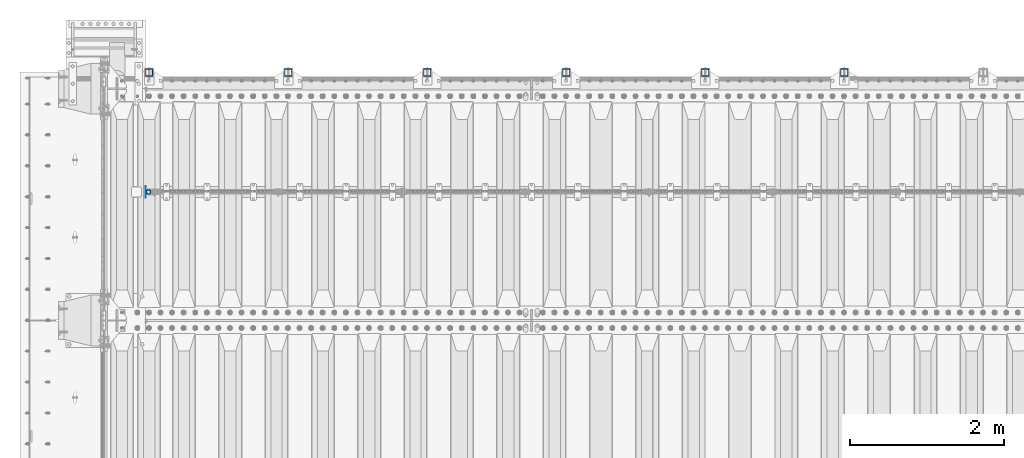
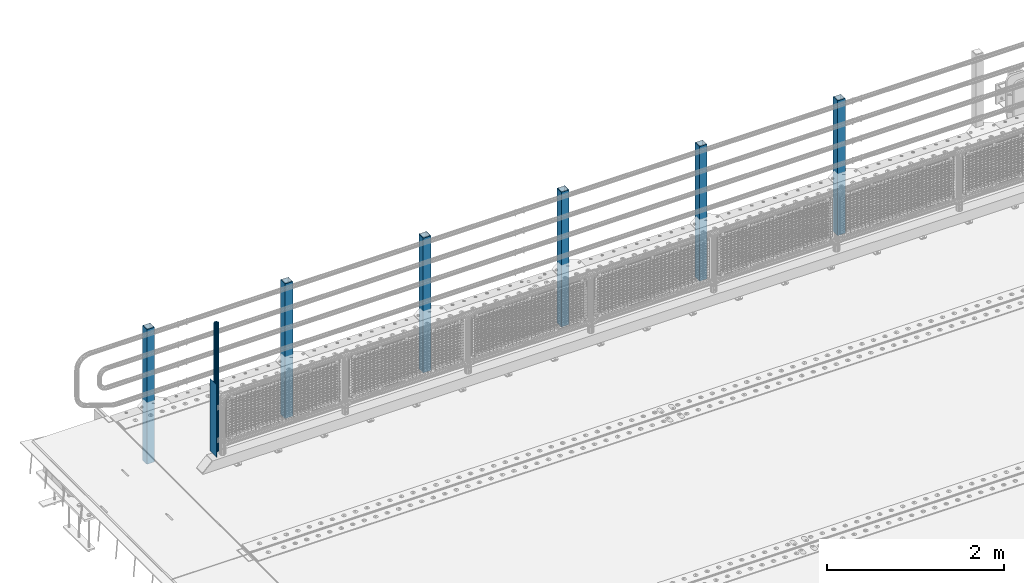
# One storey, part 61 of 257: 8 columns.
"""IFC2X3 building model written with IfcOpenShell, lengths in millimetres."""

import ifcopenshell
import ifcopenshell.guid

model = None  # the IFC model being written
_history = None  # IfcOwnerHistory: only IFC2X3 demands one
_inside = {}  # id of a spatial element -> (the spatial element, [elements in it])
_under = {}  # id of a project, library or spatial element -> (it, [spatial elements below it])
_declared = {}  # id of a project -> (the project, [libraries it declares])
_typed = {}  # id of a type object -> (the type object, [elements of that type])
_made_of = {}  # id of a material, layer set ... -> (it, [elements and type objects made of it])


def new_model(schema):
    """Start an empty IFC model of exactly this schema.

    Asked for "IFC4X3", IfcOpenShell would pick the latest addendum, in which some entities
    have other attributes; the version numbers below select the first issue.
    IFC2X3 requires an IfcOwnerHistory on every rooted entity: one is made here for all.
    """
    global model, _history
    if schema == "IFC4X3":
        model = ifcopenshell.file(schema_version=(4, 3, 0, 0))
    else:
        model = ifcopenshell.file(schema=schema)
    _inside.clear()
    _under.clear()
    _declared.clear()
    _typed.clear()
    _made_of.clear()
    _history = None
    if model.schema == "IFC2X3":
        org = make("IfcOrganization", Name="unknown")
        user = make(
            "IfcPersonAndOrganization",
            ThePerson=make("IfcPerson", FamilyName="unknown"),
            TheOrganization=org,
        )
        app = make(
            "IfcApplication",
            ApplicationDeveloper=org,
            Version="unknown",
            ApplicationFullName="unknown",
            ApplicationIdentifier="unknown",
        )
        _history = make(
            "IfcOwnerHistory",
            OwningUser=user,
            OwningApplication=app,
            ChangeAction="ADDED",
            CreationDate=0,
        )
    return model


def make(cls, **values):
    """One entity of the class cls with the attributes given. An attribute that is None is left unset."""
    return model.create_entity(
        cls, **{name: value for name, value in values.items() if value is not None}
    )


def rooted(cls, **values):
    """An entity with a GlobalId (a new one), such as an element, a storey or a relation."""
    return make(cls, GlobalId=ifcopenshell.guid.new(), OwnerHistory=_history, **values)


def si_unit(unit_type, name, prefix=None):
    """IfcSIUnit, for example si_unit("LENGTHUNIT", "METRE", prefix="MILLI")."""
    return make("IfcSIUnit", UnitType=unit_type, Prefix=prefix, Name=name)


def assignment(units):
    """IfcUnitAssignment: the units of a project."""
    return None if units is None else make("IfcUnitAssignment", Units=units)


def point(xyz):
    """IfcCartesianPoint."""
    return None if xyz is None else make("IfcCartesianPoint", Coordinates=xyz)


def direction(xyz):
    """IfcDirection."""
    return None if xyz is None else make("IfcDirection", DirectionRatios=xyz)


def frame(location, z_axis=None, x_axis=None):
    """IfcAxis2Placement3D, a coordinate frame: its origin and axes. An axis left out is left unset."""
    return make(
        "IfcAxis2Placement3D",
        Location=point(location),
        Axis=direction(z_axis),
        RefDirection=direction(x_axis),
    )


def origin_with_axes():
    """The frame at (0, 0, 0) with the z axis (0, 0, 1) and the x axis (1, 0, 0) written out."""
    return frame((0.0, 0.0, 0.0), z_axis=(0.0, 0.0, 1.0), x_axis=(1.0, 0.0, 0.0))


def place(relative_to, where):
    """IfcLocalPlacement: puts the frame where relative to a parent placement (None: the world)."""
    return make(
        "IfcLocalPlacement", PlacementRelTo=relative_to, RelativePlacement=where
    )


def context(
    kind, dimensions, precision=None, world=None, true_north=None, identifier=None
):
    """IfcGeometricRepresentationContext, for example the 3D "Model" context."""
    return make(
        "IfcGeometricRepresentationContext",
        ContextIdentifier=identifier,
        ContextType=kind,
        CoordinateSpaceDimension=dimensions,
        Precision=precision,
        WorldCoordinateSystem=world,
        TrueNorth=true_north,
    )


def subcontext(parent, identifier, kind, view, scale=None):
    """IfcGeometricRepresentationSubContext, for example "Body" below "Model"."""
    return make(
        "IfcGeometricRepresentationSubContext",
        ContextIdentifier=identifier,
        ContextType=kind,
        ParentContext=parent,
        TargetScale=scale,
        TargetView=view,
    )


def project(units=None, contexts=None):
    """IfcProject with its units and contexts."""
    return rooted(
        "IfcProject",
        Name="project",
        RepresentationContexts=contexts,
        UnitsInContext=assignment(units),
    )


def spatial(cls, under=None, at=None, **own):
    """A site, building, storey or space (cls), placed at a placement, below another one or the project."""
    s = rooted(cls, ObjectPlacement=at, **own)
    if under is not None:
        _under.setdefault(under.id(), (under, []))[1].append(s)
    return s


def faces_of(points, faces, orient=None, outer=None):
    """IfcFace entities. A face is a list of loops; a loop is a list of indices into points, from 0.

    orient and outer hold one flag for each loop. By default every Orientation is true, the
    first loop of a face is its IfcFaceOuterBound and the others are IfcFaceBound.
    """
    made = []
    for i, loops in enumerate(faces):
        bounds = []
        for j, loop in enumerate(loops):
            is_outer = j == 0 if outer is None else outer[i][j]
            bounds.append(
                make(
                    "IfcFaceOuterBound" if is_outer else "IfcFaceBound",
                    Bound=make("IfcPolyLoop", Polygon=[points[k] for k in loop]),
                    Orientation=True if orient is None else orient[i][j],
                )
            )
        made.append(make("IfcFace", Bounds=bounds))
    return made


def faceted_brep(points, faces, orient=None, outer=None, voids=None):
    """IfcFacetedBrep: a solid bounded by flat faces; with voids (closed shells), ...WithVoids."""
    shared = [point(p) for p in points]
    hull = make("IfcClosedShell", CfsFaces=faces_of(shared, faces, orient, outer))
    if voids is None:
        return make("IfcFacetedBrep", Outer=hull)
    return make(
        "IfcFacetedBrepWithVoids",
        Outer=hull,
        Voids=[
            make(cls, CfsFaces=faces_of(shared, fs, o, b)) for cls, fs, o, b in voids
        ],
    )


def shape(context_of_items, identifier, shape_type, items):
    """IfcShapeRepresentation: the items that make up one representation, for example the "Body"."""
    return make(
        "IfcShapeRepresentation",
        ContextOfItems=context_of_items,
        RepresentationIdentifier=identifier,
        RepresentationType=shape_type,
        Items=items,
    )


def material(Name=None, Category=None):
    """IfcMaterial."""
    return make("IfcMaterial", Name=Name, Category=Category)


def made_of(thing, what):
    """Note that an element or type object is made of a material, layer set ...; save() writes the relation."""
    if what is not None:
        _made_of.setdefault(what.id(), (what, []))[1].append(thing)
    return thing


def type_object(cls, material=None, **own):
    """A type object (cls), such as IfcWallType, which elements share."""
    return made_of(rooted(cls, **own), material)


def element(
    cls,
    number,
    at=None,
    inside=None,
    cuts=None,
    type_object=None,
    material=None,
    context=None,
    identifier="Body",
    shape_type=None,
    held_by="IfcProductDefinitionShape",
    body=None,
    shapes=None,
    **own,
):
    """One element of the class cls, such as IfcWall. Its Tag is "e" and its number.

    at: its placement. inside: the storey or other place that contains it. cuts: it is an
    opening in that element (IfcRelVoidsElement). A single representation is given by context,
    identifier, shape_type and body (its items); several are given by shapes. held_by: the class
    of the entity that holds the representations. save() writes the other relations.
    """
    e = rooted(cls, Tag="e%d" % number, ObjectPlacement=at, **own)
    if body is not None:
        shapes = [shape(context, identifier, shape_type, body)]
    if shapes is not None:
        e.Representation = make(held_by, Representations=shapes)
    if inside is not None:
        _inside.setdefault(inside.id(), (inside, []))[1].append(e)
    if cuts is not None:
        rooted(
            "IfcRelVoidsElement", RelatingBuildingElement=cuts, RelatedOpeningElement=e
        )
    if type_object is not None:
        _typed.setdefault(type_object.id(), (type_object, []))[1].append(e)
    return made_of(e, material)


def aggregate(whole, parts):
    """IfcRelAggregates: a whole, such as a stair, and the parts it consists of."""
    return rooted("IfcRelAggregates", RelatingObject=whole, RelatedObjects=parts)


def save(model, path):
    """Write the relations noted so far, then the file.

    IfcRelAggregates (storeys below a building ...), IfcRelContainedInSpatialStructure (elements
    in a storey), IfcRelDefinesByType, IfcRelAssociatesMaterial and IfcRelDeclares: one each for
    every whole, place, type object, material and project.
    """
    for whole, parts in _under.values():
        aggregate(whole, parts)
    for where, things in _inside.values():
        rooted(
            "IfcRelContainedInSpatialStructure",
            RelatedElements=things,
            RelatingStructure=where,
        )
    for kind, things in _typed.values():
        rooted("IfcRelDefinesByType", RelatedObjects=things, RelatingType=kind)
    for what, things in _made_of.values():
        rooted("IfcRelAssociatesMaterial", RelatedObjects=things, RelatingMaterial=what)
    for by, libraries in _declared.values():
        rooted("IfcRelDeclares", RelatingContext=by, RelatedDefinitions=libraries)
    model.write(path)


model = new_model("IFC2X3")

# Units and contexts
model_context = context("Model", 3, precision=1e-05, world=origin_with_axes())
body_context = subcontext(model_context, "Body", "Model", "MODEL_VIEW")
ifc_project = project(units=[si_unit("LENGTHUNIT", "METRE", prefix="MILLI"), si_unit("AREAUNIT", "SQUARE_METRE"), si_unit("VOLUMEUNIT", "CUBIC_METRE"), si_unit("MASSUNIT", "GRAM", prefix="KILO"), si_unit("TIMEUNIT", "SECOND"), si_unit("PLANEANGLEUNIT", "RADIAN"), si_unit("SOLIDANGLEUNIT", "STERADIAN"), si_unit("THERMODYNAMICTEMPERATUREUNIT", "DEGREE_CELSIUS"), si_unit("LUMINOUSINTENSITYUNIT", "LUMEN")], contexts=[model_context])

# Site, building, storey
site_placement = place(None, origin_with_axes())
site = spatial("IfcSite", under=ifc_project, at=site_placement, CompositionType="ELEMENT")
building_placement = place(site_placement, origin_with_axes())
building = spatial("IfcBuilding", under=site, at=building_placement, Name="Standard", CompositionType="ELEMENT")
storey_placement = place(building_placement, origin_with_axes())
storey = spatial("IfcBuildingStorey", under=building, at=storey_placement, Name="Undefined", CompositionType="ELEMENT", Elevation=0.0)

# Columns
ifc_material_1 = material(Name="Misc_Undefined")
column_type_1 = type_object("IfcColumnType", PredefinedType="NOTDEFINED")
column_1_placement = place(storey_placement, frame((42991.0, 10664.5, 238.02), z_axis=(1.0, 0.0, 0.0), x_axis=(0.0, 0.0, 1.0)))
element("IfcColumn", 1, at=column_1_placement, inside=storey, type_object=column_type_1, material=ifc_material_1, context=body_context, shape_type="Brep", body=[
    faceted_brep([(0.0, -25.3500000000004, 0.0), (0.0, -23.4203461491616, 9.70102501045767), (1761.98, -23.4203461491616, 9.70102501045767), (1761.98, -25.3500000000004, 0.0), (0.0, -17.9251569030785, 17.9251569030821), (1761.98, -17.9251569030785, 17.9251569030821), (0.0, -9.70102501045585, 23.4203461491634), (1761.98, -9.70102501045585, 23.4203461491634), (0.0, 0.0, 25.3499999999985), (1761.98, 0.0, 25.3499999999985), (0.0, 9.70102501045585, 23.4203461491634), (1761.98, 9.70102501045585, 23.4203461491634), (0.0, 17.9251569030785, 17.9251569030821), (1761.98, 17.9251569030785, 17.9251569030821), (0.0, 23.4203461491616, 9.70102501045767), (1761.98, 23.4203461491616, 9.70102501045767), (0.0, 25.3500000000004, 0.0), (1761.98, 25.3500000000004, 0.0), (0.0, 23.4203461491616, -9.70102501045767), (1761.98, 23.4203461491616, -9.70102501045767), (0.0, 17.9251569030785, -17.9251569030821), (1761.98, 17.9251569030785, -17.9251569030821), (0.0, 9.70102501045585, -23.4203461491634), (1761.98, 9.70102501045585, -23.4203461491634), (0.0, 0.0, -25.3499999999985), (1761.98, 0.0, -25.3499999999985), (0.0, -9.70102501045585, -23.4203461491634), (1761.98, -9.70102501045585, -23.4203461491634), (0.0, -17.9251569030785, -17.9251569030821), (1761.98, -17.9251569030785, -17.9251569030821), (0.0, -23.4203461491616, -9.70102501045767), (1761.98, -23.4203461491616, -9.70102501045767), (0.0, -30.1499999999996, 0.0), (0.0, -27.8549679052157, -11.5379054858058), (1761.98, -27.8549679052157, -11.5379054858058), (1761.98, -30.1499999999996, 0.0), (0.0, -21.3192694527752, -21.3192694527752), (1761.98, -21.3192694527752, -21.3192694527752), (0.0, -11.5379054858076, -27.8549679052157), (1761.98, -11.5379054858076, -27.8549679052157), (0.0, 0.0, -30.1500000000015), (1761.98, 0.0, -30.1500000000015), (0.0, 11.5379054858076, -27.8549679052157), (1761.98, 11.5379054858076, -27.8549679052157), (0.0, 21.3192694527752, -21.3192694527752), (1761.98, 21.3192694527752, -21.3192694527752), (0.0, 27.8549679052157, -11.5379054858058), (1761.98, 27.8549679052157, -11.5379054858058), (0.0, 30.1499999999996, 0.0), (1761.98, 30.1499999999996, 0.0), (0.0, 27.8549679052157, 11.5379054858058), (1761.98, 27.8549679052157, 11.5379054858058), (0.0, 21.3192694527752, 21.3192694527752), (1761.98, 21.3192694527752, 21.3192694527752), (0.0, 11.5379054858076, 27.8549679052157), (1761.98, 11.5379054858076, 27.8549679052157), (0.0, 0.0, 30.1500000000015), (1761.98, 0.0, 30.1500000000015), (0.0, -11.5379054858076, 27.8549679052157), (1761.98, -11.5379054858076, 27.8549679052157), (0.0, -21.3192694527752, 21.3192694527752), (1761.98, -21.3192694527752, 21.3192694527752), (0.0, -27.8549679052157, 11.5379054858058), (1761.98, -27.8549679052157, 11.5379054858058)], [[[0, 1, 2, 3]], [[1, 4, 5, 2]], [[4, 6, 7, 5]], [[6, 8, 9, 7]], [[8, 10, 11, 9]], [[10, 12, 13, 11]], [[12, 14, 15, 13]], [[14, 16, 17, 15]], [[16, 18, 19, 17]], [[18, 20, 21, 19]], [[20, 22, 23, 21]], [[22, 24, 25, 23]], [[24, 26, 27, 25]], [[26, 28, 29, 27]], [[28, 30, 31, 29]], [[30, 0, 3, 31]], [[32, 33, 34, 35]], [[33, 36, 37, 34]], [[36, 38, 39, 37]], [[38, 40, 41, 39]], [[40, 42, 43, 41]], [[42, 44, 45, 43]], [[44, 46, 47, 45]], [[46, 48, 49, 47]], [[48, 50, 51, 49]], [[50, 52, 53, 51]], [[52, 54, 55, 53]], [[54, 56, 57, 55]], [[56, 58, 59, 57]], [[58, 60, 61, 59]], [[60, 62, 63, 61]], [[62, 32, 35, 63]], [[37, 39, 41, 43, 45, 47, 49, 51, 53, 55, 57, 59, 61, 63, 35, 34], [5, 7, 9, 11, 13, 15, 17, 19, 21, 23, 25, 27, 29, 31, 3, 2]], [[62, 60, 58, 56, 54, 52, 50, 48, 46, 44, 42, 40, 38, 36, 33, 32], [30, 28, 26, 24, 22, 20, 18, 16, 14, 12, 10, 8, 6, 4, 1, 0]]]),
])
column_type_2 = type_object("IfcColumnType", PredefinedType="NOTDEFINED")
column_2_placement = place(storey_placement, frame((42954.5, 10664.5, 200.0), z_axis=(0.0, 1.0, 0.0), x_axis=(0.0, 0.0, 1.0)))
element("IfcColumn", 2, at=column_2_placement, inside=storey, type_object=column_type_2, material=ifc_material_1, context=body_context, shape_type="Brep", body=[
    faceted_brep([(0.0, 1.5, -75.0), (0.0, 1.5, 75.0), (1000.0, 1.5, 75.0), (1000.0, 1.5, -75.0), (0.0, -1.5, 75.0), (1000.0, -1.5, 75.0), (0.0, -1.5, -75.0), (1000.0, -1.5, -75.0)], [[[0, 1, 2, 3]], [[1, 4, 5, 2]], [[4, 6, 7, 5]], [[6, 0, 3, 7]], [[5, 7, 3, 2]], [[6, 4, 1, 0]]]),
])
ifc_material_2 = material()
column_type_3 = type_object("IfcColumnType", PredefinedType="NOTDEFINED")
for number, where, z_axis, x_axis in (
    (3, (52000.0000000001, 12210.0000000002, -844.999999999998), (0.0, -1.0, 0.0), (0.0, 0.0, 1.0)),
    (4, (50200.0000000001, 12210.0000000002, -844.999999999998), (0.0, -1.0, 0.0), (0.0, 0.0, 1.0)),
    (5, (48400.0000000001, 12210.0000000002, -844.999999999998), (0.0, -1.0, 0.0), (0.0, 0.0, 1.0)),
    (6, (46600.0000000001, 12210.0000000002, -844.999999999998), (0.0, -1.0, 0.0), (0.0, 0.0, 1.0)),
    (7, (44800.0000000001, 12210.0000000002, -844.999999999998), (0.0, -1.0, 0.0), (0.0, 0.0, 1.0)),
    (8, (43000.0000000001, 12210.0000000002, -844.999999999998), (0.0, -1.0, 0.0), (0.0, 0.0, 1.0)),
):
    element("IfcColumn", number, at=place(storey_placement, frame(where, z_axis=z_axis, x_axis=x_axis)), inside=storey, type_object=column_type_3, material=ifc_material_2, context=body_context, shape_type="Brep", body=[
        faceted_brep([(0.0, 40.0, -40.0), (0.0, -40.0, -40.0), (1855.0, -40.0, -40.0), (1855.0, 40.0, -40.0), (0.0, -40.0, 40.0), (1855.0, -40.0, 40.0), (0.0, 40.0, 40.0), (1855.0, 40.0, 40.0), (0.0, 50.0, -50.0), (0.0, 50.0, 50.0), (1855.0, 50.0, 50.0), (1855.0, 50.0, -50.0), (0.0, -50.0, 50.0), (1855.0, -50.0, 50.0), (0.0, -50.0, -50.0), (1855.0, -50.0, -50.0)], [[[0, 1, 2, 3]], [[1, 4, 5, 2]], [[4, 6, 7, 5]], [[6, 0, 3, 7]], [[8, 9, 10, 11]], [[9, 12, 13, 10]], [[12, 14, 15, 13]], [[14, 8, 11, 15]], [[13, 15, 11, 10], [5, 7, 3, 2]], [[14, 12, 9, 8], [6, 4, 1, 0]]]),
    ])

save(model, "model.ifc")
